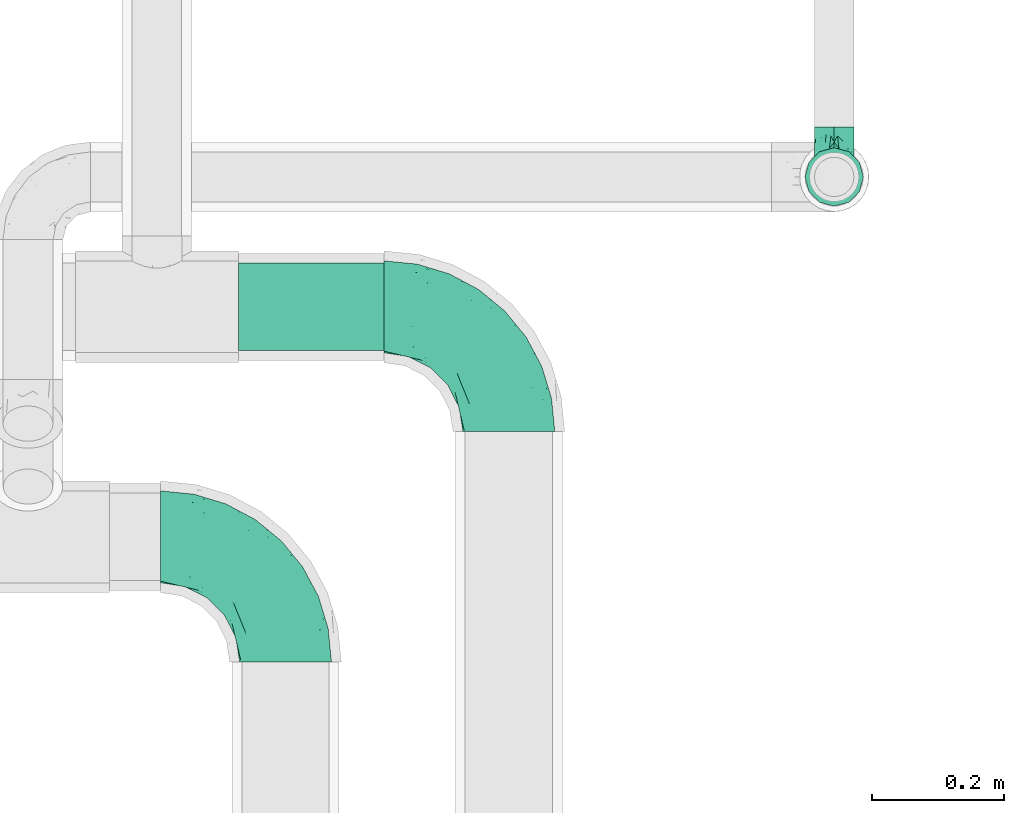
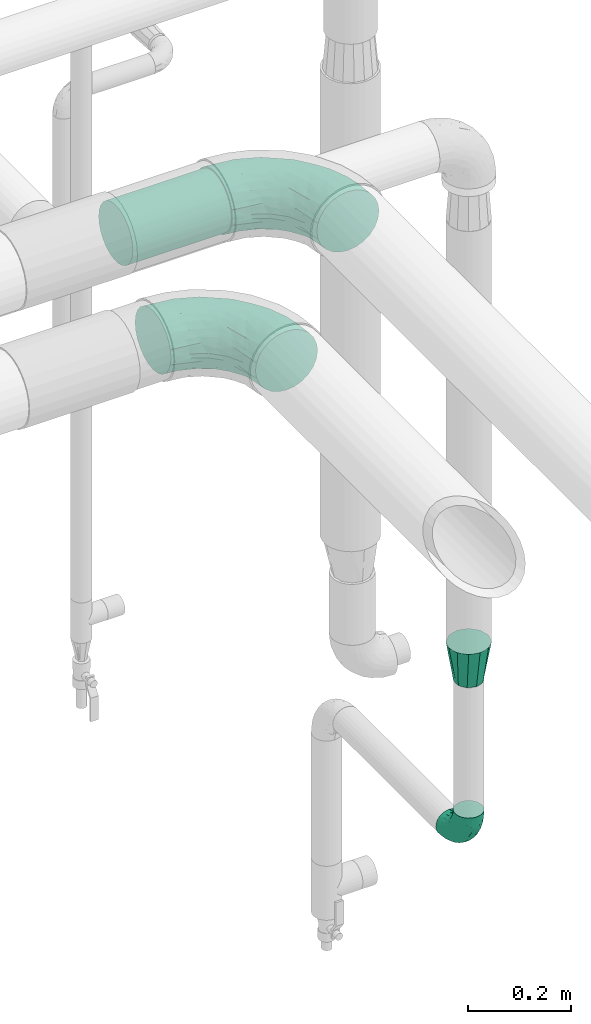
# One storey, part 584 of 827: 4 flow fittings, 1 flow segment.
"""IFC2X3 building model written with IfcOpenShell, lengths in millimetres."""

from ifc_helpers import new_model, entity, si_unit, converted_unit, derived_unit, direction, frame, origin, origin_2d_with_axis, place, context, subcontext, project, spatial, circle, extrude, faceted_brep, source, transform, mapped, material, type_object, type_shapes, element, save


model = new_model("IFC2X3")

# Units and contexts
model_context = context("Model", 3, precision=0.01, world=origin(), true_north=direction((6.12303176911189e-17, 1.0)))
body_context = subcontext(model_context, "Body", "Model", "MODEL_VIEW")
ifc_project = project(units=[si_unit("LENGTHUNIT", "METRE", prefix="MILLI"), si_unit("AREAUNIT", "SQUARE_METRE"), si_unit("VOLUMEUNIT", "CUBIC_METRE"), converted_unit("PLANEANGLEUNIT", "DEGREE", entity("IfcRatioMeasure", 0.0174532925199433), si_unit("PLANEANGLEUNIT", "RADIAN"), dimensions=[0, 0, 0, 0, 0, 0, 0]), si_unit("MASSUNIT", "GRAM", prefix="KILO"), derived_unit("MASSDENSITYUNIT", [(si_unit("MASSUNIT", "GRAM", prefix="KILO"), 1), (si_unit("LENGTHUNIT", "METRE"), -3)]), derived_unit("MOMENTOFINERTIAUNIT", [(si_unit("LENGTHUNIT", "METRE"), 4)]), si_unit("TIMEUNIT", "SECOND"), si_unit("FREQUENCYUNIT", "HERTZ"), si_unit("THERMODYNAMICTEMPERATUREUNIT", "DEGREE_CELSIUS"), derived_unit("THERMALTRANSMITTANCEUNIT", [(si_unit("MASSUNIT", "GRAM", prefix="KILO"), 1), (si_unit("THERMODYNAMICTEMPERATUREUNIT", "KELVIN"), -1), (si_unit("TIMEUNIT", "SECOND"), -3)]), derived_unit("VOLUMETRICFLOWRATEUNIT", [(si_unit("LENGTHUNIT", "METRE"), 3), (si_unit("TIMEUNIT", "SECOND"), -1)]), derived_unit("MASSFLOWRATEUNIT", [(si_unit("MASSUNIT", "GRAM", prefix="KILO"), 1), (si_unit("TIMEUNIT", "SECOND"), -1)]), derived_unit("ROTATIONALFREQUENCYUNIT", [(si_unit("TIMEUNIT", "SECOND"), -1)]), si_unit("ELECTRICCURRENTUNIT", "AMPERE"), si_unit("ELECTRICVOLTAGEUNIT", "VOLT"), si_unit("POWERUNIT", "WATT"), si_unit("FORCEUNIT", "NEWTON", prefix="KILO"), si_unit("ILLUMINANCEUNIT", "LUX"), si_unit("LUMINOUSFLUXUNIT", "LUMEN"), si_unit("LUMINOUSINTENSITYUNIT", "CANDELA"), derived_unit("USERDEFINED", [(si_unit("MASSUNIT", "GRAM", prefix="KILO"), -1), (si_unit("LENGTHUNIT", "METRE"), -2), (si_unit("TIMEUNIT", "SECOND"), 3), (si_unit("LUMINOUSFLUXUNIT", "LUMEN"), 1)]), derived_unit("LINEARVELOCITYUNIT", [(si_unit("LENGTHUNIT", "METRE"), 1), (si_unit("TIMEUNIT", "SECOND"), -1)]), si_unit("PRESSUREUNIT", "PASCAL"), derived_unit("USERDEFINED", [(si_unit("LENGTHUNIT", "METRE"), -2), (si_unit("MASSUNIT", "GRAM", prefix="KILO"), 1), (si_unit("TIMEUNIT", "SECOND"), -2)]), derived_unit("LINEARFORCEUNIT", [(si_unit("MASSUNIT", "GRAM", prefix="KILO"), 1), (si_unit("LENGTHUNIT", "METRE"), 1), (si_unit("TIMEUNIT", "SECOND"), -2), (si_unit("LENGTHUNIT", "METRE"), -1)]), derived_unit("PLANARFORCEUNIT", [(si_unit("MASSUNIT", "GRAM", prefix="KILO"), 1), (si_unit("LENGTHUNIT", "METRE"), 1), (si_unit("TIMEUNIT", "SECOND"), -2), (si_unit("LENGTHUNIT", "METRE"), -2)])], contexts=[model_context])

# Site, building, storey
site_placement = place(None, origin())
site = spatial("IfcSite", under=ifc_project, at=site_placement, CompositionType="ELEMENT")
building_placement = place(site_placement, origin())
building = spatial("IfcBuilding", under=site, at=building_placement, CompositionType="ELEMENT")
storey_placement = place(building_placement, frame((0.0, 0.0, 28200.0)))
storey = spatial("IfcBuildingStorey", under=building, at=storey_placement, Name="08", CompositionType="ELEMENT", Elevation=28200.0)

# Flow segment
pipe_segment_type = type_object("IfcPipeSegmentType", PredefinedType="NOTDEFINED")
flow_segment_placement = place(storey_placement, frame((21763.46, 14681.7, 2731.9)))
element("IfcFlowSegment", 1, at=flow_segment_placement, inside=storey, type_object=pipe_segment_type, context=body_context, shape_type="SweptSolid", body=[
    extrude(circle(Radius=66.5, at=origin_2d_with_axis()), frame((0.0, 68.1, 68.1), z_axis=(1.0, 0.0, 0.0), x_axis=(0.0, 1.0, 0.0)), (0.0, 0.0, 1.0), 221.302481480755),
])

# Flow fittings
ifc_material = material()
pipe_fitting_type_1 = type_object("IfcPipeFittingType", Name="ADSK_1", PredefinedType="NOTDEFINED", material=ifc_material)
shared_shape_1 = source(origin(), body_context, "Body", "Brep", [
    faceted_brep([(-76.0, 15.07, -26.11), (-76.0, 7.8, -29.12), (-76.0, 0.0, -30.15), (-76.0, -7.8, -29.12), (-76.0, -15.08, -26.11), (-76.0, -21.32, -21.32), (-76.0, -26.11, -15.08), (-76.0, -29.12, -7.8), (-76.0, -30.15, 0.0), (-76.0, -29.12, 7.8), (-76.0, -26.11, 15.07), (-76.0, -21.32, 21.32), (-76.0, -15.08, 26.11), (-76.0, -7.8, 29.12), (-76.0, 0.0, 30.15), (-76.0, 7.8, 29.12), (-76.0, 15.07, 26.11), (-76.0, 21.32, 21.32), (-76.0, 26.11, 15.07), (-76.0, 29.12, 7.8), (-76.0, 30.15, 0.0), (-76.0, 29.12, -7.8), (-76.0, 26.11, -15.08), (-76.0, 21.32, -21.32), (0.0, 76.0, -30.15), (-7.8, 76.0, -29.12), (-15.07, 76.0, -26.11), (-21.32, 76.0, -21.32), (-26.11, 76.0, -15.08), (-29.12, 76.0, -7.8), (-30.15, 76.0, 0.0), (-29.12, 76.0, 7.8), (-26.11, 76.0, 15.07), (-21.32, 76.0, 21.32), (-15.07, 76.0, 26.11), (-7.8, 76.0, 29.12), (0.0, 76.0, 30.15), (7.8, 76.0, 29.12), (15.08, 76.0, 26.11), (21.32, 76.0, 21.32), (26.11, 76.0, 15.07), (29.12, 76.0, 7.8), (30.15, 76.0, 0.0), (29.12, 76.0, -7.8), (26.11, 76.0, -15.08), (21.32, 76.0, -21.32), (15.08, 76.0, -26.11), (7.8, 76.0, -29.12), (10.79, 31.43, 21.07), (4.32, 31.7, 25.72), (1.65, 15.19, 19.92), (-61.17, -27.8, 0.0), (-51.1, -25.49, 9.84), (-56.14, -10.61, 27.27), (-31.7, -4.32, 25.72), (-39.75, 1.72, 29.41), (-43.2, -24.95, 0.0), (-1.86, 1.86, 0.0), (4.49, 7.65, 5.78), (-7.82, -4.61, 5.83), (-56.21, -22.79, 17.21), (-58.98, -3.38, 29.7), (-53.96, 5.6, 30.07), (-10.86, 10.86, 25.48), (-17.2, -2.6, 20.44), (-49.15, -16.01, 22.7), (-22.18, -14.24, 7.99), (-28.4, -17.42, 0.0), (-13.61, -9.88, 0.0), (-39.0, 23.48, 27.76), (-58.76, 12.54, 28.36), (-41.61, 15.41, 29.48), (16.01, 49.15, 22.7), (-58.55, 25.93, 19.53), (-51.53, 33.5, 13.51), (-64.92, 28.76, 12.4), (-7.48, 23.14, 28.25), (-1.72, 39.75, 29.41), (-12.04, 27.88, 29.88), (-63.91, 18.81, 24.52), (-11.63, 65.16, 28.18), (-4.97, 57.02, 30.05), (9.88, 13.61, 0.0), (-62.5, 31.74, 5.02), (-45.17, 30.98, 21.2), (-21.78, 9.76, 28.58), (10.61, 56.14, 27.27), (-32.09, 54.42, 13.26), (22.79, 56.21, 17.21), (15.38, 31.17, 15.63), (25.49, 51.1, 9.84), (21.84, 36.35, 5.92), (24.95, 43.2, 0.0), (3.38, 58.98, 29.7), (-31.17, -15.38, 15.63), (-39.39, 41.78, 15.45), (-34.56, 41.13, 20.79), (-39.81, -23.25, 5.49), (27.8, 61.17, 0.0), (-31.74, 62.5, 5.02), (-53.07, 36.29, 0.0), (-42.95, 42.95, 7.29), (-36.29, 53.07, 0.0), (-19.83, 58.51, 24.79), (-25.48, 60.2, 19.41), (-14.53, 50.96, 28.57), (-13.31, 37.09, 30.07), (-26.16, 40.06, 26.4), (-32.43, -10.35, 21.9), (17.42, 28.4, 0.0), (14.24, 22.18, 7.99), (-38.67, 9.72, 30.15), (-24.66, 17.36, 30.09), (-37.08, 31.49, 24.99), (-49.27, 22.83, 25.24), (-20.8, 38.81, 28.63), (-27.58, 27.58, 29.2), (-36.07, -20.23, 10.71), (-15.19, -6.16, 14.9), (6.6, 15.4, 14.49), (-2.51, 2.51, 11.35), (-65.16, 11.63, -28.18), (-49.15, -16.01, -22.7), (-57.02, 4.97, -30.05), (-25.93, 58.55, -19.53), (-33.5, 51.53, -13.51), (-28.76, 64.92, -12.4), (-60.2, 25.48, -19.41), (-58.51, 19.83, -24.79), (4.61, 7.82, -5.83), (-7.65, -4.49, -5.78), (-2.51, 2.51, -11.35), (-62.5, 31.74, -5.02), (-50.96, 14.53, -28.57), (-37.09, 13.31, -30.07), (-42.95, 42.95, -7.29), (25.49, 51.1, -9.84), (22.79, 56.21, -17.21), (-40.06, 26.16, -26.4), (3.38, 58.98, -29.7), (-5.6, 53.96, -30.07), (-27.88, 12.04, -29.88), (-9.76, 21.78, -28.58), (-23.14, 7.48, -28.25), (-51.1, -25.49, -9.84), (15.38, 31.17, -15.63), (16.01, 49.15, -22.7), (-23.48, 39.0, -27.76), (-12.54, 58.76, -28.36), (-15.41, 41.61, -29.48), (-56.21, -22.79, -17.21), (-9.72, 38.67, -30.15), (-17.36, 24.66, -30.09), (-22.18, -14.24, -7.99), (-41.13, 34.56, -20.79), (-31.74, 62.5, -5.02), (-58.98, -3.38, -29.7), (-31.17, -15.38, -15.63), (-56.14, -10.61, -27.27), (14.24, 22.18, -7.99), (23.25, 39.81, -5.49), (-31.49, 37.08, -24.99), (-15.19, -6.16, -14.9), (1.65, 15.19, -19.92), (-18.81, 63.91, -24.52), (-32.59, -11.62, -20.84), (-31.7, -4.32, -25.72), (-17.2, -2.6, -20.44), (-39.75, 1.72, -29.41), (-54.42, 32.09, -13.26), (-30.98, 45.17, -21.2), (10.61, 56.14, -27.27), (10.23, 31.31, -21.52), (4.32, 31.7, -25.72), (-41.78, 39.39, -15.45), (-1.72, 39.75, -29.41), (-36.35, -21.84, -5.92), (-22.83, 49.27, -25.24), (-38.81, 20.8, -28.63), (-27.58, 27.58, -29.2), (-10.86, 10.86, -25.48), (20.23, 36.07, -10.71), (6.6, 15.4, -14.49)], [[[0, 1, 2, 3, 4, 5, 6, 7, 8, 9, 10, 11, 12, 13, 14, 15, 16, 17, 18, 19, 20, 21, 22, 23]], [[24, 25, 26, 27, 28, 29, 30, 31, 32, 33, 34, 35, 36, 37, 38, 39, 40, 41, 42, 43, 44, 45, 46, 47]], [[48, 49, 50]], [[51, 52, 9]], [[53, 54, 55]], [[9, 52, 10]], [[56, 52, 51]], [[57, 58, 59]], [[11, 10, 60]], [[14, 61, 62]], [[63, 54, 64]], [[65, 12, 11]], [[65, 53, 12]], [[66, 67, 68]], [[69, 70, 71]], [[72, 39, 38]], [[73, 74, 75]], [[15, 70, 16]], [[76, 77, 78]], [[16, 79, 17]], [[13, 61, 14]], [[35, 80, 81]], [[14, 62, 15]], [[17, 73, 18]], [[57, 82, 58]], [[20, 19, 83]], [[75, 19, 18]], [[70, 15, 62]], [[73, 84, 74]], [[78, 85, 76]], [[38, 86, 72]], [[32, 31, 87]], [[88, 89, 90]], [[91, 92, 90]], [[72, 86, 49]], [[36, 93, 37]], [[75, 83, 19]], [[36, 35, 81]], [[60, 94, 65]], [[40, 90, 41]], [[95, 96, 87]], [[88, 90, 40]], [[66, 97, 67]], [[90, 98, 41]], [[40, 39, 88]], [[99, 31, 30]], [[20, 83, 100]], [[101, 102, 100]], [[52, 60, 10]], [[102, 99, 30]], [[96, 103, 104]], [[83, 101, 100]], [[12, 53, 13]], [[104, 103, 33]], [[105, 106, 81]], [[107, 105, 103]], [[64, 54, 108]], [[80, 103, 105]], [[80, 35, 34]], [[34, 33, 103]], [[86, 38, 37]], [[109, 110, 82]], [[71, 111, 112]], [[69, 107, 113]], [[79, 73, 17]], [[114, 113, 84]], [[33, 32, 104]], [[115, 107, 116]], [[105, 115, 106]], [[93, 81, 77]], [[54, 53, 65]], [[61, 53, 55]], [[108, 94, 64]], [[54, 63, 85]], [[93, 86, 37]], [[77, 76, 49]], [[77, 49, 86]], [[49, 63, 50]], [[60, 52, 117]], [[65, 11, 60]], [[39, 72, 88]], [[89, 88, 72]], [[71, 70, 62]], [[79, 70, 114]], [[103, 96, 107]], [[69, 113, 114]], [[112, 106, 116]], [[77, 81, 106]], [[112, 116, 71]], [[112, 55, 85]], [[64, 50, 63]], [[57, 59, 68]], [[32, 87, 104]], [[96, 104, 87]], [[94, 118, 64]], [[50, 119, 89]], [[50, 64, 118]], [[50, 89, 48]], [[81, 93, 36]], [[86, 93, 77]], [[53, 61, 13]], [[62, 61, 55]], [[71, 62, 111]], [[69, 71, 116]], [[95, 101, 74]], [[99, 101, 87]], [[118, 66, 59]], [[117, 97, 66]], [[117, 66, 94]], [[91, 89, 110]], [[91, 110, 109]], [[110, 89, 119]], [[9, 8, 51]], [[98, 90, 92]], [[98, 42, 41]], [[101, 83, 74]], [[101, 99, 102]], [[87, 31, 99]], [[62, 55, 111]], [[55, 112, 111]], [[107, 69, 116]], [[70, 69, 114]], [[107, 96, 113]], [[84, 113, 96]], [[84, 96, 95]], [[114, 84, 73]], [[70, 79, 16]], [[73, 79, 114]], [[54, 85, 55]], [[76, 85, 63]], [[49, 76, 63]], [[77, 106, 78]], [[106, 112, 78]], [[85, 78, 112]], [[73, 75, 18]], [[83, 75, 74]], [[103, 80, 34]], [[81, 80, 105]], [[101, 95, 87]], [[84, 95, 74]], [[106, 115, 116]], [[105, 107, 115]], [[120, 59, 58]], [[82, 110, 58]], [[119, 58, 110]], [[118, 59, 120]], [[66, 68, 59]], [[54, 65, 108]], [[94, 108, 65]], [[66, 118, 94]], [[50, 118, 120]], [[50, 120, 119]], [[119, 120, 58]], [[89, 72, 48]], [[49, 48, 72]], [[60, 117, 94]], [[117, 52, 97]], [[52, 56, 97]], [[67, 97, 56]], [[92, 91, 109]], [[89, 91, 90]], [[121, 1, 0]], [[122, 5, 4]], [[2, 1, 123]], [[124, 125, 126]], [[127, 128, 23]], [[129, 130, 131]], [[100, 132, 20]], [[133, 134, 123]], [[135, 100, 102]], [[136, 137, 44]], [[133, 128, 138]], [[24, 139, 140]], [[141, 142, 143]], [[121, 128, 133]], [[6, 144, 7]], [[137, 145, 146]], [[144, 51, 7]], [[147, 148, 149]], [[144, 6, 150]], [[149, 151, 152]], [[153, 68, 67]], [[154, 128, 127]], [[30, 155, 102]], [[43, 42, 98]], [[156, 3, 2]], [[157, 144, 150]], [[158, 4, 3]], [[24, 140, 25]], [[155, 135, 102]], [[159, 160, 109]], [[30, 29, 155]], [[147, 138, 161]], [[27, 124, 28]], [[57, 129, 82]], [[162, 163, 131]], [[27, 26, 164]], [[148, 26, 25]], [[165, 166, 167]], [[24, 47, 139]], [[143, 168, 141]], [[22, 21, 169]], [[125, 124, 170]], [[148, 25, 140]], [[46, 146, 171]], [[158, 122, 4]], [[0, 23, 128]], [[1, 121, 123]], [[109, 82, 159]], [[45, 44, 137]], [[146, 46, 45]], [[136, 43, 98]], [[132, 21, 20]], [[136, 98, 92]], [[172, 173, 146]], [[46, 171, 47]], [[43, 136, 44]], [[174, 154, 169]], [[171, 173, 175]], [[6, 5, 150]], [[126, 29, 28]], [[176, 56, 144]], [[122, 158, 166]], [[164, 124, 27]], [[177, 161, 170]], [[23, 22, 127]], [[178, 138, 179]], [[133, 178, 134]], [[156, 123, 168]], [[156, 158, 3]], [[168, 143, 166]], [[168, 166, 158]], [[166, 180, 167]], [[173, 171, 146]], [[139, 171, 175]], [[172, 145, 163]], [[173, 180, 142]], [[5, 122, 150]], [[157, 150, 122]], [[137, 136, 181]], [[146, 45, 137]], [[149, 148, 140]], [[164, 148, 177]], [[128, 154, 138]], [[147, 161, 177]], [[152, 134, 179]], [[168, 123, 134]], [[152, 179, 149]], [[152, 175, 142]], [[57, 130, 129]], [[157, 165, 167]], [[22, 169, 127]], [[154, 127, 169]], [[163, 167, 180]], [[162, 157, 167]], [[173, 163, 180]], [[182, 163, 145]], [[123, 156, 2]], [[158, 156, 168]], [[171, 139, 47]], [[140, 139, 175]], [[149, 140, 151]], [[147, 149, 179]], [[174, 135, 125]], [[132, 135, 169]], [[176, 157, 153]], [[176, 153, 67]], [[153, 157, 162]], [[182, 159, 129]], [[181, 160, 159]], [[181, 159, 145]], [[51, 144, 56]], [[51, 8, 7]], [[135, 132, 100]], [[169, 21, 132]], [[126, 155, 29]], [[135, 155, 125]], [[140, 175, 151]], [[175, 152, 151]], [[138, 147, 179]], [[148, 147, 177]], [[138, 154, 161]], [[170, 161, 154]], [[170, 154, 174]], [[177, 170, 124]], [[148, 164, 26]], [[124, 164, 177]], [[173, 142, 175]], [[143, 142, 180]], [[166, 143, 180]], [[168, 134, 141]], [[134, 152, 141]], [[142, 141, 152]], [[124, 126, 28]], [[155, 126, 125]], [[128, 121, 0]], [[123, 121, 133]], [[135, 174, 169]], [[170, 174, 125]], [[134, 178, 179]], [[133, 138, 178]], [[130, 153, 162]], [[68, 153, 130]], [[57, 68, 130]], [[182, 129, 131]], [[159, 82, 129]], [[157, 122, 165]], [[166, 165, 122]], [[163, 162, 167]], [[162, 131, 130]], [[145, 172, 146]], [[163, 173, 172]], [[159, 182, 145]], [[131, 163, 182]], [[56, 176, 67]], [[157, 176, 144]], [[137, 181, 145]], [[181, 136, 160]], [[136, 92, 160]], [[109, 160, 92]]]),
])
type_shapes(pipe_fitting_type_1, [shared_shape_1])
flow_fitting_1_placement = place(storey_placement, frame((22669.46, 14947.25, 920.55), z_axis=(-1.0, 0.0, 0.0), x_axis=(0.0, -1.0, 0.0)))
element("IfcFlowFitting", 2, at=flow_fitting_1_placement, inside=storey, type_object=pipe_fitting_type_1, material=ifc_material, Name="ADSK_1", ObjectType="ADSK_1", context=body_context, shape_type="MappedRepresentation", body=[
    mapped(shared_shape_1, transform((0.0, 0.0, 0.0), scale=1.0)),
])
pipe_fitting_type_2 = type_object("IfcPipeFittingType", Name="ADSK_1", PredefinedType="NOTDEFINED", material=ifc_material)
shared_shape_2 = source(origin(), body_context, "Body", "Brep", [
    faceted_brep([(-190.0, 18.08, -67.47), (-190.0, 0.0, -69.85), (-190.0, -18.08, -67.47), (-190.0, -34.93, -60.49), (-190.0, -49.39, -49.39), (-190.0, -60.49, -34.93), (-190.0, -67.47, -18.08), (-190.0, -69.85, 0.0), (-190.0, -67.47, 18.08), (-190.0, -60.49, 34.92), (-190.0, -49.39, 49.39), (-190.0, -34.93, 60.49), (-190.0, -18.08, 67.47), (-190.0, 0.0, 69.85), (-190.0, 18.08, 67.47), (-190.0, 34.92, 60.49), (-190.0, 49.39, 49.39), (-190.0, 60.49, 34.92), (-190.0, 67.47, 18.08), (-190.0, 69.85, 0.0), (-190.0, 67.47, -18.08), (-190.0, 60.49, -34.93), (-190.0, 49.39, -49.39), (-190.0, 34.92, -60.49), (18.08, 190.0, -67.47), (0.0, 190.0, -69.85), (-18.08, 190.0, -67.47), (-34.92, 190.0, -60.49), (-49.39, 190.0, -49.39), (-60.49, 190.0, -34.93), (-67.47, 190.0, -18.08), (-69.85, 190.0, 0.0), (-67.47, 190.0, 18.08), (-60.49, 190.0, 34.92), (-49.39, 190.0, 49.39), (-34.92, 190.0, 60.49), (-18.08, 190.0, 67.47), (0.0, 190.0, 69.85), (18.08, 190.0, 67.47), (34.93, 190.0, 60.49), (49.39, 190.0, 49.39), (60.49, 190.0, 34.92), (67.47, 190.0, 18.08), (69.85, 190.0, 0.0), (67.47, 190.0, -18.08), (60.49, 190.0, -34.93), (49.39, 190.0, -49.39), (34.93, 190.0, -60.49), (-29.62, 146.98, 65.62), (-13.75, 135.37, 69.64), (-124.22, -36.33, 52.83), (-140.23, -52.18, 40.04), (-80.56, -34.09, 36.78), (-140.97, -24.01, 63.29), (-80.93, -8.05, 59.8), (-100.59, 5.62, 68.24), (-125.19, -57.65, 22.9), (-139.31, -64.86, 0.0), (-28.7, -8.91, 22.6), (-45.64, -26.06, 0.0), (-6.26, 6.26, 0.0), (-105.44, 36.89, 68.2), (-118.83, 43.56, 64.34), (-146.98, 29.62, 65.62), (-71.47, -38.86, 17.07), (-90.56, -50.07, 0.0), (-0.6, 27.02, 35.97), (-44.76, -2.31, 47.74), (-42.86, -12.1, 35.78), (-148.03, -7.38, 68.85), (-135.37, 13.75, 69.64), (-67.48, 159.11, 28.79), (36.32, 124.15, 52.82), (-38.8, 102.11, 68.2), (-24.59, 96.61, 69.85), (-81.73, 130.22, 21.92), (-65.15, 30.31, 68.68), (-27.72, 54.52, 66.49), (-44.98, 61.25, 69.74), (-75.73, 152.87, 0.0), (-159.11, 67.48, 28.79), (-130.22, 81.73, 21.92), (-152.87, 75.73, 0.0), (-76.65, 126.59, 35.57), (-101.51, 101.51, 25.92), (-96.74, 96.74, 38.75), (-144.94, 60.97, 45.11), (-159.57, 43.91, 56.71), (-119.38, 92.8, 0.0), (50.07, 90.56, 0.0), (57.42, 124.25, 22.84), (38.8, 71.6, 17.49), (64.86, 139.31, 0.0), (52.17, 140.21, 40.03), (33.37, 79.39, 36.99), (24.0, 140.95, 63.29), (8.03, 80.92, 59.81), (-82.61, -22.17, 50.94), (7.38, 148.03, 68.85), (-100.26, 79.14, 51.33), (-75.76, 96.1, 55.72), (-76.12, 111.95, 46.7), (-92.8, 119.38, 0.0), (-104.27, 104.27, 12.31), (10.07, 27.17, 16.15), (26.06, 45.64, 0.0), (-61.21, 144.14, 45.16), (-44.13, 158.15, 56.77), (-55.26, 120.41, 58.38), (9.95, 57.03, 48.64), (29.48, 90.08, 47.56), (-5.62, 100.59, 68.24), (-122.78, 54.24, 58.28), (-86.25, 73.26, 61.12), (-95.79, 24.47, 69.85), (-126.59, 76.65, 35.57), (-17.15, 26.56, 50.85), (-29.82, 29.82, 59.54), (-70.73, 11.02, 65.19), (-58.6, 94.58, 64.16), (-71.14, 66.1, 67.41), (-158.15, 44.13, -56.77), (33.37, 79.39, -36.99), (10.07, 27.17, -16.15), (-0.6, 27.02, -35.97), (-100.59, 5.62, -68.24), (-148.03, -7.38, -68.85), (-135.37, 13.75, -69.64), (-130.22, 81.73, -21.92), (-146.98, 29.62, -65.62), (-102.11, 38.8, -68.2), (-96.61, 24.59, -69.85), (-83.02, -24.86, -48.76), (-44.76, -2.31, -47.74), (-80.56, -34.09, -36.78), (-122.68, -57.24, -22.15), (-71.43, -38.87, -16.95), (-104.27, 104.27, -12.31), (-159.11, 67.48, -28.79), (-144.14, 61.21, -45.16), (7.38, 148.03, -68.85), (-13.75, 135.37, -69.64), (-79.14, 100.26, -51.33), (-96.1, 75.76, -55.72), (-111.95, 76.12, -46.7), (-80.93, -8.05, -59.8), (-124.22, -36.33, -52.83), (-140.23, -52.18, -40.04), (-24.47, 95.79, -69.85), (-36.89, 105.44, -68.2), (-150.18, -65.36, -13.92), (-43.56, 118.83, -64.34), (-29.62, 146.98, -65.62), (38.8, 71.6, -17.49), (-81.73, 130.22, -21.92), (-28.7, -8.91, -22.6), (-54.24, 122.78, -58.28), (-73.26, 86.25, -61.12), (-61.25, 44.98, -69.74), (-30.31, 65.15, -68.68), (-54.52, 27.72, -66.49), (-101.51, 101.51, -25.92), (-126.59, 76.65, -35.57), (-96.74, 96.74, -38.75), (-67.48, 159.11, -28.79), (-120.41, 55.26, -58.38), (-43.91, 159.57, -56.71), (24.0, 140.95, -63.29), (8.03, 80.92, -59.81), (-5.62, 100.59, -68.24), (-60.97, 144.94, -45.11), (36.32, 124.15, -52.82), (57.42, 124.25, -22.84), (52.17, 140.21, -40.03), (-140.97, -24.01, -63.29), (9.95, 57.03, -48.64), (-76.65, 126.59, -35.57), (22.84, 89.04, -52.94), (-11.03, 70.74, -65.2), (-29.82, 29.82, -59.54), (-94.58, 58.6, -64.16), (-66.1, 71.14, -67.41), (-31.42, -3.01, -36.09), (-13.88, 24.32, -46.86)], [[[0, 1, 2, 3, 4, 5, 6, 7, 8, 9, 10, 11, 12, 13, 14, 15, 16, 17, 18, 19, 20, 21, 22, 23]], [[24, 25, 26, 27, 28, 29, 30, 31, 32, 33, 34, 35, 36, 37, 38, 39, 40, 41, 42, 43, 44, 45, 46, 47]], [[36, 48, 49]], [[50, 51, 52]], [[53, 54, 55]], [[56, 9, 8]], [[8, 7, 57]], [[58, 59, 60]], [[51, 9, 56]], [[61, 62, 63]], [[59, 58, 64]], [[59, 64, 65]], [[11, 10, 50]], [[66, 67, 68]], [[50, 53, 11]], [[69, 70, 13]], [[71, 33, 32]], [[72, 40, 39]], [[73, 74, 49]], [[63, 15, 14]], [[13, 70, 14]], [[71, 32, 75]], [[12, 69, 13]], [[76, 77, 78]], [[32, 79, 75]], [[18, 80, 81]], [[63, 14, 70]], [[82, 19, 18]], [[83, 84, 85]], [[86, 16, 87]], [[82, 81, 88]], [[82, 18, 81]], [[15, 87, 16]], [[83, 71, 75]], [[52, 56, 64]], [[49, 37, 36]], [[89, 90, 91]], [[36, 35, 48]], [[42, 41, 90]], [[89, 92, 90]], [[11, 53, 12]], [[73, 78, 74]], [[65, 56, 57]], [[40, 72, 93]], [[94, 90, 93]], [[41, 40, 93]], [[72, 95, 96]], [[95, 39, 38]], [[8, 57, 56]], [[43, 42, 92]], [[67, 54, 97]], [[38, 37, 98]], [[99, 100, 101]], [[102, 75, 79]], [[51, 10, 9]], [[102, 88, 103]], [[31, 79, 32]], [[104, 60, 105]], [[106, 34, 33]], [[84, 103, 81]], [[91, 105, 89]], [[107, 35, 34]], [[106, 108, 107]], [[49, 48, 73]], [[104, 105, 91]], [[16, 86, 17]], [[58, 104, 66]], [[109, 110, 96]], [[111, 98, 49]], [[112, 113, 99]], [[92, 42, 90]], [[95, 72, 39]], [[70, 114, 61]], [[80, 18, 17]], [[101, 106, 83]], [[99, 86, 112]], [[115, 81, 80]], [[90, 94, 91]], [[94, 66, 104]], [[64, 58, 68]], [[56, 65, 64]], [[93, 72, 110]], [[90, 41, 93]], [[98, 95, 38]], [[111, 77, 96]], [[111, 96, 95]], [[67, 116, 117]], [[52, 51, 56]], [[50, 10, 51]], [[54, 53, 50]], [[69, 53, 55]], [[97, 52, 67]], [[118, 76, 55]], [[107, 48, 35]], [[73, 119, 120]], [[61, 63, 70]], [[63, 62, 87]], [[94, 104, 91]], [[58, 60, 104]], [[109, 66, 94]], [[67, 117, 54]], [[68, 67, 52]], [[116, 66, 109]], [[119, 48, 108]], [[73, 120, 78]], [[120, 61, 114]], [[78, 114, 76]], [[49, 98, 37]], [[95, 98, 111]], [[53, 69, 12]], [[70, 69, 55]], [[70, 55, 114]], [[120, 113, 62]], [[76, 114, 55]], [[120, 114, 78]], [[118, 55, 54]], [[76, 118, 77]], [[96, 77, 117]], [[111, 78, 77]], [[54, 117, 118]], [[77, 118, 117]], [[110, 109, 94]], [[116, 96, 117]], [[106, 107, 34]], [[48, 107, 108]], [[75, 84, 83]], [[106, 33, 71]], [[101, 83, 85]], [[106, 71, 83]], [[99, 101, 85]], [[108, 106, 101]], [[99, 85, 115]], [[113, 112, 62]], [[119, 113, 120]], [[100, 99, 113]], [[17, 86, 80]], [[115, 85, 84]], [[80, 86, 115]], [[99, 115, 86]], [[63, 87, 15]], [[86, 87, 112]], [[78, 111, 74]], [[111, 49, 74]], [[119, 100, 113]], [[101, 100, 108]], [[48, 119, 73]], [[119, 108, 100]], [[75, 102, 103]], [[115, 84, 81]], [[81, 103, 88]], [[75, 103, 84]], [[54, 50, 97]], [[52, 97, 50]], [[64, 68, 52]], [[66, 68, 58]], [[62, 61, 120]], [[87, 62, 112]], [[93, 110, 94]], [[96, 110, 72]], [[66, 116, 67]], [[96, 116, 109]], [[22, 121, 23]], [[122, 123, 124]], [[125, 126, 127]], [[20, 82, 128]], [[129, 130, 127]], [[130, 131, 127]], [[19, 82, 20]], [[132, 133, 134]], [[88, 128, 82]], [[135, 136, 65]], [[102, 137, 88]], [[138, 20, 128]], [[139, 22, 21]], [[140, 141, 25]], [[142, 143, 144]], [[145, 133, 132]], [[4, 146, 147]], [[141, 148, 149]], [[7, 6, 150]], [[138, 21, 20]], [[5, 4, 147]], [[149, 151, 152]], [[59, 65, 136]], [[122, 153, 123]], [[79, 30, 154]], [[134, 155, 136]], [[150, 65, 57]], [[156, 157, 142]], [[126, 2, 1]], [[134, 135, 147]], [[130, 158, 131]], [[159, 160, 158]], [[154, 161, 137]], [[0, 23, 129]], [[127, 1, 0]], [[162, 138, 128]], [[161, 163, 162]], [[30, 79, 31]], [[146, 4, 3]], [[154, 30, 164]], [[152, 27, 26]], [[165, 121, 139]], [[25, 24, 140]], [[25, 141, 26]], [[164, 30, 29]], [[27, 166, 28]], [[167, 168, 169]], [[141, 152, 26]], [[28, 170, 29]], [[47, 171, 167]], [[172, 89, 153]], [[59, 155, 60]], [[28, 166, 170]], [[46, 45, 173]], [[153, 89, 105]], [[105, 123, 153]], [[174, 146, 3]], [[171, 47, 46]], [[45, 44, 172]], [[7, 150, 57]], [[43, 92, 44]], [[122, 124, 175]], [[89, 172, 92]], [[171, 173, 122]], [[47, 167, 24]], [[173, 171, 46]], [[135, 150, 5]], [[0, 129, 127]], [[174, 3, 2]], [[79, 154, 102]], [[146, 174, 145]], [[44, 92, 172]], [[144, 139, 162]], [[142, 170, 156]], [[176, 154, 164]], [[105, 60, 123]], [[122, 172, 153]], [[45, 172, 173]], [[122, 173, 172]], [[167, 171, 177]], [[140, 167, 169]], [[177, 122, 175]], [[178, 159, 169]], [[134, 136, 135]], [[155, 59, 136]], [[134, 147, 146]], [[135, 5, 147]], [[126, 174, 2]], [[125, 160, 145]], [[125, 145, 174]], [[145, 179, 133]], [[121, 129, 23]], [[130, 180, 181]], [[149, 152, 141]], [[152, 151, 166]], [[60, 155, 123]], [[123, 155, 124]], [[182, 134, 133]], [[175, 179, 168]], [[183, 179, 175]], [[155, 182, 124]], [[180, 129, 165]], [[130, 181, 158]], [[181, 149, 148]], [[158, 148, 159]], [[127, 126, 1]], [[174, 126, 125]], [[167, 140, 24]], [[141, 140, 169]], [[141, 169, 148]], [[181, 157, 151]], [[159, 148, 169]], [[181, 148, 158]], [[178, 169, 168]], [[159, 178, 160]], [[145, 160, 179]], [[125, 158, 160]], [[168, 179, 178]], [[160, 178, 179]], [[175, 124, 183]], [[177, 175, 168]], [[139, 121, 22]], [[129, 121, 165]], [[128, 161, 162]], [[139, 21, 138]], [[144, 162, 163]], [[139, 138, 162]], [[142, 144, 163]], [[165, 139, 144]], [[142, 163, 176]], [[157, 156, 151]], [[180, 157, 181]], [[143, 142, 157]], [[29, 170, 164]], [[176, 163, 161]], [[164, 170, 176]], [[142, 176, 170]], [[152, 166, 27]], [[170, 166, 156]], [[158, 125, 131]], [[125, 127, 131]], [[180, 143, 157]], [[144, 143, 165]], [[129, 180, 130]], [[180, 165, 143]], [[128, 88, 137]], [[176, 161, 154]], [[154, 137, 102]], [[128, 137, 161]], [[5, 150, 6]], [[65, 150, 135]], [[134, 146, 132]], [[145, 132, 146]], [[134, 182, 155]], [[183, 182, 133]], [[151, 149, 181]], [[166, 151, 156]], [[182, 183, 124]], [[179, 183, 133]], [[167, 177, 168]], [[122, 177, 171]]]),
])
type_shapes(pipe_fitting_type_2, [shared_shape_2])
for number, where, z_axis, x_axis, name in (
    (3, (22174.76, 14749.79, 2800.0), (0.0, 0.0, 1.0), (0.0, 1.0, 0.0), "ADSK_1"),
    (4, (21835.11, 14400.0, 2799.98), (0.0, 0.0, 1.0), (0.0, 1.0, 0.0), "ADSK_1"),
):
    element("IfcFlowFitting", number, at=place(storey_placement, frame(where, z_axis=z_axis, x_axis=x_axis)), inside=storey, type_object=pipe_fitting_type_2, material=ifc_material, Name=name, ObjectType="ADSK_1", context=body_context, shape_type="MappedRepresentation", body=[
        mapped(shared_shape_2, transform((0.0, 0.0, 0.0), scale=1.0)),
    ])
pipe_fitting_type_3 = type_object("IfcPipeFittingType", Name="ADSK_1", PredefinedType="NOTDEFINED", material=ifc_material)
shared_shape_3 = source(origin(), body_context, "Body", "Brep", [
    faceted_brep([(89.0, -44.45, 0.0), (89.0, -42.1, -8.76), (89.0, -38.49, -22.22), (89.0, -30.36, -30.36), (89.0, -22.23, -38.49), (89.0, -11.11, -41.47), (89.0, 0.0, -44.45), (89.0, 11.11, -41.47), (89.0, 22.22, -38.49), (89.0, 30.36, -30.36), (89.0, 38.49, -22.22), (89.0, 42.1, -8.76), (89.0, 44.45, 0.0), (89.0, 42.1, 8.76), (89.0, 38.49, 22.23), (89.0, 30.36, 30.36), (89.0, 22.22, 38.49), (89.0, 11.11, 41.47), (89.0, 0.0, 44.45), (89.0, -11.11, 41.47), (89.0, -22.23, 38.49), (89.0, -30.36, 30.36), (89.0, -38.49, 22.23), (89.0, -42.1, 8.76), (0.0, 30.15, 0.0), (0.0, 27.27, -8.86), (0.0, 24.39, -17.72), (0.0, 16.85, -23.2), (0.0, 9.32, -28.67), (0.0, 0.0, -28.67), (0.0, -9.32, -28.67), (0.0, -16.85, -23.2), (0.0, -24.39, -17.72), (0.0, -27.27, -8.86), (0.0, -30.15, 0.0), (0.0, -27.27, 8.86), (0.0, -24.39, 17.72), (0.0, -16.85, 23.2), (0.0, -9.32, 28.67), (0.0, 0.0, 28.67), (0.0, 9.32, 28.67), (0.0, 16.85, 23.2), (0.0, 24.39, 17.72), (0.0, 27.27, 8.86)], [[[0, 1, 2, 3, 4, 5, 6, 7, 8, 9, 10, 11, 12, 13, 14, 15, 16, 17, 18, 19, 20, 21, 22, 23]], [[24, 25, 26, 27, 28, 29, 30, 31, 32, 33, 34, 35, 36, 37, 38, 39, 40, 41, 42, 43]], [[2, 33, 32]], [[28, 7, 29]], [[29, 5, 30]], [[24, 12, 11]], [[3, 32, 31]], [[34, 1, 0]], [[1, 34, 33]], [[8, 28, 27]], [[2, 1, 33]], [[31, 4, 3]], [[2, 32, 3]], [[11, 25, 24]], [[26, 10, 9]], [[10, 25, 11]], [[28, 8, 7]], [[27, 26, 9]], [[26, 25, 10]], [[31, 30, 4]], [[8, 27, 9]], [[29, 7, 6]], [[5, 29, 6]], [[5, 4, 30]], [[14, 43, 42]], [[38, 19, 39]], [[39, 17, 40]], [[34, 0, 23]], [[15, 42, 41]], [[24, 13, 12]], [[13, 24, 43]], [[20, 38, 37]], [[14, 13, 43]], [[41, 16, 15]], [[14, 42, 15]], [[23, 35, 34]], [[36, 22, 21]], [[22, 35, 23]], [[38, 20, 19]], [[37, 36, 21]], [[36, 35, 22]], [[41, 40, 16]], [[20, 37, 21]], [[39, 19, 18]], [[17, 39, 18]], [[17, 16, 40]]]),
])
type_shapes(pipe_fitting_type_3, [shared_shape_3])
flow_fitting_2_placement = place(storey_placement, frame((22669.46, 14947.25, 1305.55), z_axis=(1.0, 0.0, 0.0), x_axis=(0.0, 0.0, 1.0)))
element("IfcFlowFitting", 5, at=flow_fitting_2_placement, inside=storey, type_object=pipe_fitting_type_3, material=ifc_material, Name="ADSK_1", ObjectType="ADSK_1", context=body_context, shape_type="MappedRepresentation", body=[
    mapped(shared_shape_3, transform((0.0, 0.0, 0.0), scale=1.0)),
])

save(model, "model.ifc")
